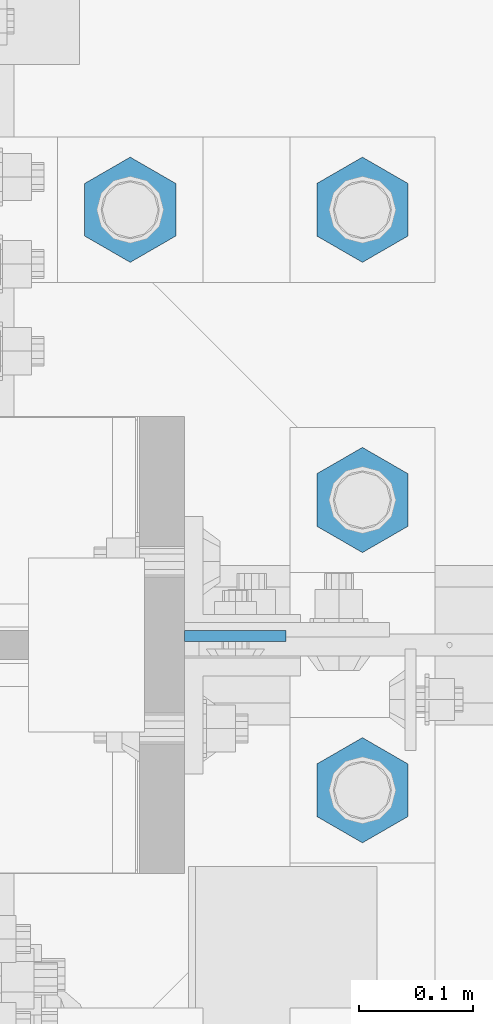
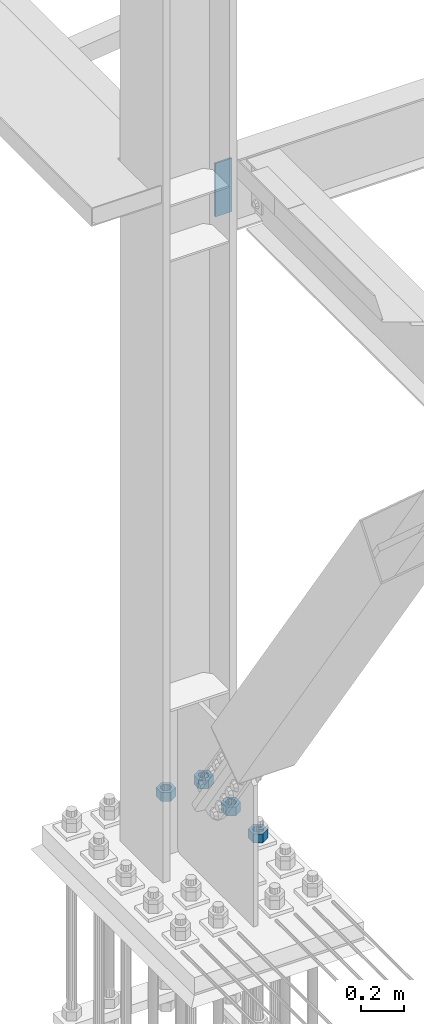
# One storey, part 1528 of 3843: 5 columns, 2 elements without a shape of their own.
"""IFC2X3 building model written with IfcOpenShell, lengths in millimetres."""

from ifc_helpers import new_model, si_unit, frame, origin_with_axes, place, context, subcontext, project, spatial, faceted_brep, material, type_object, element, aggregate, save


model = new_model("IFC2X3")

# Units and contexts
model_context = context("Model", 3, precision=1e-05, world=origin_with_axes())
body_context = subcontext(model_context, "Body", "Model", "MODEL_VIEW")
ifc_project = project(units=[si_unit("LENGTHUNIT", "METRE", prefix="MILLI"), si_unit("AREAUNIT", "SQUARE_METRE"), si_unit("VOLUMEUNIT", "CUBIC_METRE"), si_unit("MASSUNIT", "GRAM", prefix="KILO"), si_unit("TIMEUNIT", "SECOND"), si_unit("PLANEANGLEUNIT", "RADIAN"), si_unit("SOLIDANGLEUNIT", "STERADIAN"), si_unit("THERMODYNAMICTEMPERATUREUNIT", "DEGREE_CELSIUS"), si_unit("LUMINOUSINTENSITYUNIT", "LUMEN")], contexts=[model_context])

# Site, building, storey
site_placement = place(None, origin_with_axes())
site = spatial("IfcSite", under=ifc_project, at=site_placement, CompositionType="ELEMENT")
building_placement = place(site_placement, origin_with_axes())
building = spatial("IfcBuilding", under=site, at=building_placement, Name="Undefined", CompositionType="ELEMENT")
storey_placement = place(building_placement, origin_with_axes())
storey = spatial("IfcBuildingStorey", under=building, at=storey_placement, Name="Undefined", CompositionType="ELEMENT", Elevation=0.0)

# Assembly, column
assembly_1_placement = place(storey_placement, origin_with_axes())
assembly_1 = element("IfcElementAssembly", 1, at=assembly_1_placement, inside=storey, Name="COLUMN", AssemblyPlace="NOTDEFINED", PredefinedType="RIGID_FRAME")
ifc_material = material(Name="STEEL/A572-50")
column_type_1 = type_object("IfcColumnType", PredefinedType="NOTDEFINED")
column_1_placement = place(assembly_1_placement, frame((36820.475, 58923.2375, 33693.0999993376), z_axis=(-1.0, 0.0, 0.0), x_axis=(0.0, 0.0, 1.0)))
column_1 = element("IfcColumn", 2, at=column_1_placement, type_object=column_type_1, material=ifc_material, Name="PLATE", context=body_context, shape_type="Brep", body=[
    faceted_brep([(0.0, 4.76249999999709, -44.4500000000007), (0.0, 4.76249999999709, 44.4500000000007), (304.799999999996, 4.76249999999709, 44.4500000000007), (304.799999999996, 4.76249999999709, -44.4500000000007), (0.0, -4.76249999999709, 44.4500000000007), (304.799999999996, -4.76249999999709, 44.4500000000007), (0.0, -4.76249999999709, -44.4500000000007), (304.799999999996, -4.76249999999709, -44.4500000000007)], [[[0, 1, 2, 3]], [[1, 4, 5, 2]], [[4, 6, 7, 5]], [[6, 0, 3, 7]], [[5, 7, 3, 2]], [[6, 4, 1, 0]]]),
])
aggregate(assembly_1, [column_1])

# Assembly, columns
assembly_2_placement = place(storey_placement, origin_with_axes())
assembly_2 = element("IfcElementAssembly", 3, at=assembly_2_placement, inside=storey, Name="TEMPLATE", AssemblyPlace="NOTDEFINED", PredefinedType="RIGID_FRAME")
column_type_2 = type_object("IfcColumnType", Name="2_HEAVY_HEX_NUT", PredefinedType="NOTDEFINED")
column_2_placement = place(assembly_2_placement, frame((36931.6, 58788.3, 30232.35), z_axis=(1.0, 0.0, 0.0), x_axis=(0.0, 0.0, -1.0)))
column_2 = element("IfcColumn", 4, at=column_2_placement, type_object=column_type_2, material=ifc_material, Name="NUT", ObjectType="2_HEAVY_HEX_NUT", context=body_context, shape_type="Brep", body=[
    faceted_brep([(0.0, -46.0369987487793, 0.0), (0.0, -23.0184993743896, -39.869213104248), (50.7999999999993, -23.0184993743896, -39.869213104248), (50.7999999999993, -46.0369987487793, 0.0), (0.0, 23.0184993743896, -39.869213104248), (50.7999999999993, 23.0184993743896, -39.869213104248), (0.0, 46.0369987487793, 0.0), (50.7999999999993, 46.0369987487793, 0.0), (0.0, 23.0184993743896, 39.869213104248), (50.7999999999993, 23.0184993743896, 39.869213104248), (0.0, -23.0184993743896, 39.869213104248), (50.7999999999993, -23.0184993743896, 39.869213104248), (0.0, 0.0, 26.1940002441406), (0.0, 11.3650617044477, 23.5999013092805), (50.7999999999993, 11.3650617044477, 23.5999013092805), (50.7999999999993, 0.0, 26.1940002441406), (0.0, 20.4791109456419, 16.3316083006721), (50.7999999999993, 20.4791109456419, 16.3316083006721), (0.0, 25.5370200498292, 5.82867859874386), (50.7999999999993, 25.5370200498292, 5.82867859874386), (0.0, 25.5370200498292, -5.82867859874386), (50.7999999999993, 25.5370200498292, -5.82867859874386), (0.0, 20.4791109456419, -16.3316083006721), (50.7999999999993, 20.4791109456419, -16.3316083006721), (0.0, 11.3650617044477, -23.5999013092805), (50.7999999999993, 11.3650617044477, -23.5999013092805), (0.0, 0.0, -26.1940002441406), (50.7999999999993, 0.0, -26.1940002441406), (0.0, -11.3650617044477, -23.5999013092805), (50.7999999999993, -11.3650617044477, -23.5999013092805), (0.0, -20.4791109456419, -16.3316083006721), (50.7999999999993, -20.4791109456419, -16.3316083006721), (0.0, -25.5370200498292, -5.82867859874386), (50.7999999999993, -25.5370200498292, -5.82867859874386), (0.0, -25.5370200498292, 5.82867859874386), (50.7999999999993, -25.5370200498292, 5.82867859874386), (0.0, -20.4791109456419, 16.3316083006721), (50.7999999999993, -20.4791109456419, 16.3316083006721), (0.0, -11.3650617044477, 23.5999013092805), (50.7999999999993, -11.3650617044477, 23.5999013092805)], [[[0, 1, 2, 3]], [[1, 4, 5, 2]], [[4, 6, 7, 5]], [[6, 8, 9, 7]], [[8, 10, 11, 9]], [[10, 0, 3, 11]], [[12, 13, 14, 15]], [[13, 16, 17, 14]], [[16, 18, 19, 17]], [[18, 20, 21, 19]], [[20, 22, 23, 21]], [[22, 24, 25, 23]], [[24, 26, 27, 25]], [[26, 28, 29, 27]], [[28, 30, 31, 29]], [[30, 32, 33, 31]], [[32, 34, 35, 33]], [[34, 36, 37, 35]], [[36, 38, 39, 37]], [[38, 12, 15, 39]], [[5, 7, 9, 11, 3, 2], [17, 19, 21, 23, 25, 27, 29, 31, 33, 35, 37, 39, 15, 14]], [[10, 8, 6, 4, 1, 0], [38, 36, 34, 32, 30, 28, 26, 24, 22, 20, 18, 16, 13, 12]]]),
])
column_3_placement = place(assembly_2_placement, frame((36931.6, 59042.3, 30232.35), z_axis=(-1.0, 0.0, 0.0), x_axis=(0.0, 0.0, -1.0)))
column_3 = element("IfcColumn", 5, at=column_3_placement, type_object=column_type_2, material=ifc_material, Name="NUT", ObjectType="2_HEAVY_HEX_NUT", context=body_context, shape_type="Brep", body=[
    faceted_brep([(0.0, -46.0369987487793, 0.0), (0.0, -23.0184993743896, -39.869213104248), (50.7999999999993, -23.0184993743896, -39.869213104248), (50.7999999999993, -46.0369987487793, 0.0), (0.0, 23.0184993743896, -39.869213104248), (50.7999999999993, 23.0184993743896, -39.869213104248), (0.0, 46.0369987487793, 0.0), (50.7999999999993, 46.0369987487793, 0.0), (0.0, 23.0184993743896, 39.869213104248), (50.7999999999993, 23.0184993743896, 39.869213104248), (0.0, -23.0184993743896, 39.869213104248), (50.7999999999993, -23.0184993743896, 39.869213104248), (0.0, 0.0, 26.1940002441406), (0.0, 11.3650617044477, 23.5999013092805), (50.7999999999993, 11.3650617044477, 23.5999013092805), (50.7999999999993, 0.0, 26.1940002441406), (0.0, 20.4791109456419, 16.3316083006721), (50.7999999999993, 20.4791109456419, 16.3316083006721), (0.0, 25.5370200498292, 5.82867859874386), (50.7999999999993, 25.5370200498292, 5.82867859874386), (0.0, 25.5370200498292, -5.82867859874386), (50.7999999999993, 25.5370200498292, -5.82867859874386), (0.0, 20.4791109456419, -16.3316083006721), (50.7999999999993, 20.4791109456419, -16.3316083006721), (0.0, 11.3650617044477, -23.5999013092805), (50.7999999999993, 11.3650617044477, -23.5999013092805), (0.0, 0.0, -26.1940002441406), (50.7999999999993, 0.0, -26.1940002441406), (0.0, -11.3650617044477, -23.5999013092805), (50.7999999999993, -11.3650617044477, -23.5999013092805), (0.0, -20.4791109456419, -16.3316083006721), (50.7999999999993, -20.4791109456419, -16.3316083006721), (0.0, -25.5370200498292, -5.82867859874386), (50.7999999999993, -25.5370200498292, -5.82867859874386), (0.0, -25.5370200498292, 5.82867859874386), (50.7999999999993, -25.5370200498292, 5.82867859874386), (0.0, -20.4791109456419, 16.3316083006721), (50.7999999999993, -20.4791109456419, 16.3316083006721), (0.0, -11.3650617044477, 23.5999013092805), (50.7999999999993, -11.3650617044477, 23.5999013092805)], [[[0, 1, 2, 3]], [[1, 4, 5, 2]], [[4, 6, 7, 5]], [[6, 8, 9, 7]], [[8, 10, 11, 9]], [[10, 0, 3, 11]], [[12, 13, 14, 15]], [[13, 16, 17, 14]], [[16, 18, 19, 17]], [[18, 20, 21, 19]], [[20, 22, 23, 21]], [[22, 24, 25, 23]], [[24, 26, 27, 25]], [[26, 28, 29, 27]], [[28, 30, 31, 29]], [[30, 32, 33, 31]], [[32, 34, 35, 33]], [[34, 36, 37, 35]], [[36, 38, 39, 37]], [[38, 12, 15, 39]], [[5, 7, 9, 11, 3, 2], [17, 19, 21, 23, 25, 27, 29, 31, 33, 35, 37, 39, 15, 14]], [[10, 8, 6, 4, 1, 0], [38, 36, 34, 32, 30, 28, 26, 24, 22, 20, 18, 16, 13, 12]]]),
])
column_4_placement = place(assembly_2_placement, frame((36931.6, 59296.3, 30232.35), z_axis=(-1.0, 0.0, 0.0), x_axis=(0.0, 0.0, -1.0)))
column_4 = element("IfcColumn", 6, at=column_4_placement, type_object=column_type_2, material=ifc_material, Name="NUT", ObjectType="2_HEAVY_HEX_NUT", context=body_context, shape_type="Brep", body=[
    faceted_brep([(0.0, -46.0369987487793, 0.0), (0.0, -23.0184993743896, -39.869213104248), (50.7999999999993, -23.0184993743896, -39.869213104248), (50.7999999999993, -46.0369987487793, 0.0), (0.0, 23.0184993743896, -39.869213104248), (50.7999999999993, 23.0184993743896, -39.869213104248), (0.0, 46.0369987487793, 0.0), (50.7999999999993, 46.0369987487793, 0.0), (0.0, 23.0184993743896, 39.869213104248), (50.7999999999993, 23.0184993743896, 39.869213104248), (0.0, -23.0184993743896, 39.869213104248), (50.7999999999993, -23.0184993743896, 39.869213104248), (0.0, 0.0, 26.1940002441406), (0.0, 11.3650617044477, 23.5999013092805), (50.7999999999993, 11.3650617044477, 23.5999013092805), (50.7999999999993, 0.0, 26.1940002441406), (0.0, 20.4791109456419, 16.3316083006721), (50.7999999999993, 20.4791109456419, 16.3316083006721), (0.0, 25.5370200498292, 5.82867859874386), (50.7999999999993, 25.5370200498292, 5.82867859874386), (0.0, 25.5370200498292, -5.82867859874386), (50.7999999999993, 25.5370200498292, -5.82867859874386), (0.0, 20.4791109456419, -16.3316083006721), (50.7999999999993, 20.4791109456419, -16.3316083006721), (0.0, 11.3650617044477, -23.5999013092805), (50.7999999999993, 11.3650617044477, -23.5999013092805), (0.0, 0.0, -26.1940002441406), (50.7999999999993, 0.0, -26.1940002441406), (0.0, -11.3650617044477, -23.5999013092805), (50.7999999999993, -11.3650617044477, -23.5999013092805), (0.0, -20.4791109456419, -16.3316083006721), (50.7999999999993, -20.4791109456419, -16.3316083006721), (0.0, -25.5370200498292, -5.82867859874386), (50.7999999999993, -25.5370200498292, -5.82867859874386), (0.0, -25.5370200498292, 5.82867859874386), (50.7999999999993, -25.5370200498292, 5.82867859874386), (0.0, -20.4791109456419, 16.3316083006721), (50.7999999999993, -20.4791109456419, 16.3316083006721), (0.0, -11.3650617044477, 23.5999013092805), (50.7999999999993, -11.3650617044477, 23.5999013092805)], [[[0, 1, 2, 3]], [[1, 4, 5, 2]], [[4, 6, 7, 5]], [[6, 8, 9, 7]], [[8, 10, 11, 9]], [[10, 0, 3, 11]], [[12, 13, 14, 15]], [[13, 16, 17, 14]], [[16, 18, 19, 17]], [[18, 20, 21, 19]], [[20, 22, 23, 21]], [[22, 24, 25, 23]], [[24, 26, 27, 25]], [[26, 28, 29, 27]], [[28, 30, 31, 29]], [[30, 32, 33, 31]], [[32, 34, 35, 33]], [[34, 36, 37, 35]], [[36, 38, 39, 37]], [[38, 12, 15, 39]], [[5, 7, 9, 11, 3, 2], [17, 19, 21, 23, 25, 27, 29, 31, 33, 35, 37, 39, 15, 14]], [[10, 8, 6, 4, 1, 0], [38, 36, 34, 32, 30, 28, 26, 24, 22, 20, 18, 16, 13, 12]]]),
])
column_5_placement = place(assembly_2_placement, frame((36728.4, 59296.3, 30232.35), z_axis=(-1.0, 0.0, 0.0), x_axis=(0.0, 0.0, -1.0)))
column_5 = element("IfcColumn", 7, at=column_5_placement, type_object=column_type_2, material=ifc_material, Name="NUT", ObjectType="2_HEAVY_HEX_NUT", context=body_context, shape_type="Brep", body=[
    faceted_brep([(0.0, -46.0369987487793, 0.0), (0.0, -23.0184993743896, -39.869213104248), (50.7999999999993, -23.0184993743896, -39.869213104248), (50.7999999999993, -46.0369987487793, 0.0), (0.0, 23.0184993743896, -39.869213104248), (50.7999999999993, 23.0184993743896, -39.869213104248), (0.0, 46.0369987487793, 0.0), (50.7999999999993, 46.0369987487793, 0.0), (0.0, 23.0184993743896, 39.869213104248), (50.7999999999993, 23.0184993743896, 39.869213104248), (0.0, -23.0184993743896, 39.869213104248), (50.7999999999993, -23.0184993743896, 39.869213104248), (0.0, 0.0, 26.1940002441406), (0.0, 11.3650617044477, 23.5999013092805), (50.7999999999993, 11.3650617044477, 23.5999013092805), (50.7999999999993, 0.0, 26.1940002441406), (0.0, 20.4791109456419, 16.3316083006721), (50.7999999999993, 20.4791109456419, 16.3316083006721), (0.0, 25.5370200498292, 5.82867859874386), (50.7999999999993, 25.5370200498292, 5.82867859874386), (0.0, 25.5370200498292, -5.82867859874386), (50.7999999999993, 25.5370200498292, -5.82867859874386), (0.0, 20.4791109456419, -16.3316083006721), (50.7999999999993, 20.4791109456419, -16.3316083006721), (0.0, 11.3650617044477, -23.5999013092805), (50.7999999999993, 11.3650617044477, -23.5999013092805), (0.0, 0.0, -26.1940002441406), (50.7999999999993, 0.0, -26.1940002441406), (0.0, -11.3650617044477, -23.5999013092805), (50.7999999999993, -11.3650617044477, -23.5999013092805), (0.0, -20.4791109456419, -16.3316083006721), (50.7999999999993, -20.4791109456419, -16.3316083006721), (0.0, -25.5370200498292, -5.82867859874386), (50.7999999999993, -25.5370200498292, -5.82867859874386), (0.0, -25.5370200498292, 5.82867859874386), (50.7999999999993, -25.5370200498292, 5.82867859874386), (0.0, -20.4791109456419, 16.3316083006721), (50.7999999999993, -20.4791109456419, 16.3316083006721), (0.0, -11.3650617044477, 23.5999013092805), (50.7999999999993, -11.3650617044477, 23.5999013092805)], [[[0, 1, 2, 3]], [[1, 4, 5, 2]], [[4, 6, 7, 5]], [[6, 8, 9, 7]], [[8, 10, 11, 9]], [[10, 0, 3, 11]], [[12, 13, 14, 15]], [[13, 16, 17, 14]], [[16, 18, 19, 17]], [[18, 20, 21, 19]], [[20, 22, 23, 21]], [[22, 24, 25, 23]], [[24, 26, 27, 25]], [[26, 28, 29, 27]], [[28, 30, 31, 29]], [[30, 32, 33, 31]], [[32, 34, 35, 33]], [[34, 36, 37, 35]], [[36, 38, 39, 37]], [[38, 12, 15, 39]], [[5, 7, 9, 11, 3, 2], [17, 19, 21, 23, 25, 27, 29, 31, 33, 35, 37, 39, 15, 14]], [[10, 8, 6, 4, 1, 0], [38, 36, 34, 32, 30, 28, 26, 24, 22, 20, 18, 16, 13, 12]]]),
])
aggregate(assembly_2, [column_2, column_3, column_4, column_5])

save(model, "model.ifc")
